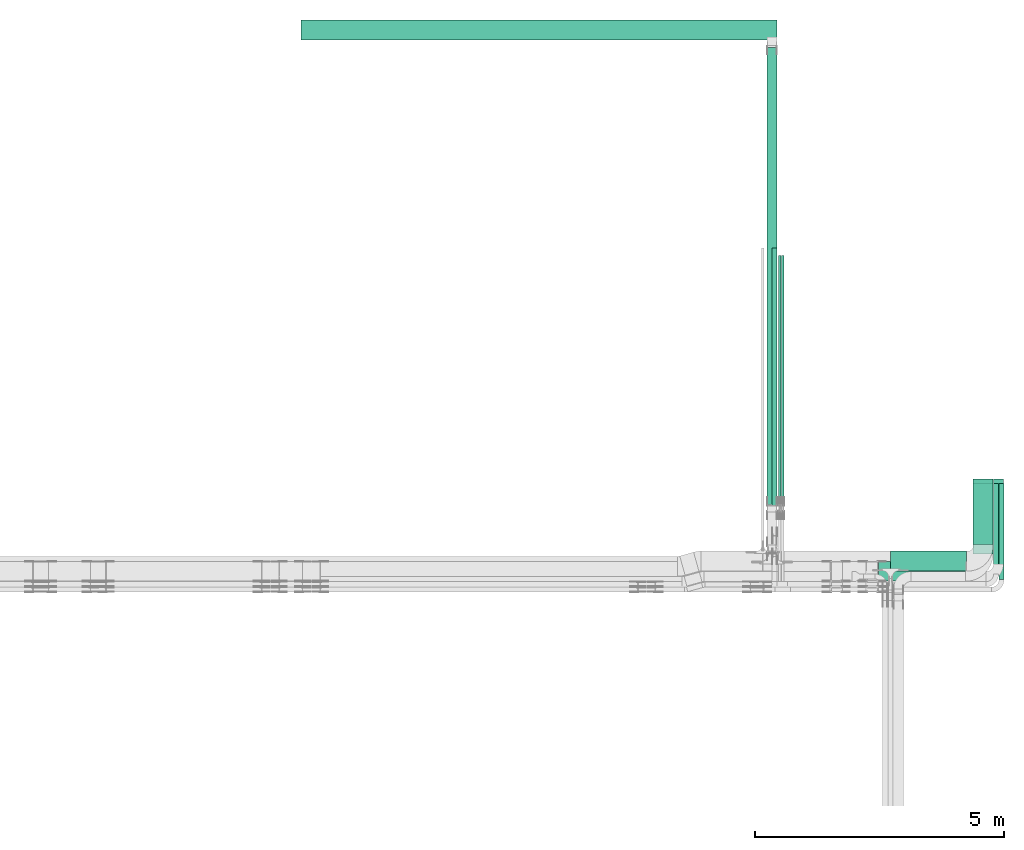
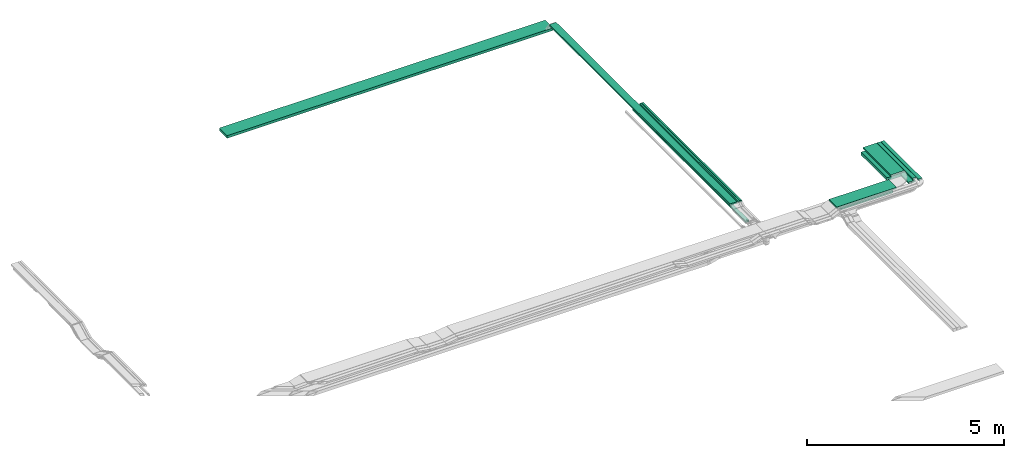
# One storey, part 3 of 27: 12 flow segments.
"""IFC2X3 building model written with IfcOpenShell, lengths in millimetres."""

from ifc_helpers import new_model, entity, si_unit, converted_unit, derived_unit, direction, frame, origin, origin_2d_with_axis, place, context, subcontext, project, spatial, rectangle, extrude, type_object, element, save


model = new_model("IFC2X3")

# Units and contexts
model_context = context("Model", 3, precision=0.01, world=origin(), true_north=direction((6.12303176911189e-17, 1.0)))
body_context = subcontext(model_context, "Body", "Model", "MODEL_VIEW")
ifc_project = project(units=[si_unit("LENGTHUNIT", "METRE", prefix="MILLI"), si_unit("AREAUNIT", "SQUARE_METRE"), si_unit("VOLUMEUNIT", "CUBIC_METRE"), converted_unit("PLANEANGLEUNIT", "DEGREE", entity("IfcRatioMeasure", 0.0174532925199433), si_unit("PLANEANGLEUNIT", "RADIAN"), dimensions=[0, 0, 0, 0, 0, 0, 0]), si_unit("MASSUNIT", "GRAM", prefix="KILO"), derived_unit("MASSDENSITYUNIT", [(si_unit("MASSUNIT", "GRAM", prefix="KILO"), 1), (si_unit("LENGTHUNIT", "METRE"), -3)]), derived_unit("MOMENTOFINERTIAUNIT", [(si_unit("LENGTHUNIT", "METRE"), 4)]), si_unit("TIMEUNIT", "SECOND"), si_unit("FREQUENCYUNIT", "HERTZ"), si_unit("THERMODYNAMICTEMPERATUREUNIT", "DEGREE_CELSIUS"), derived_unit("THERMALTRANSMITTANCEUNIT", [(si_unit("MASSUNIT", "GRAM", prefix="KILO"), 1), (si_unit("THERMODYNAMICTEMPERATUREUNIT", "KELVIN"), -1), (si_unit("TIMEUNIT", "SECOND"), -3)]), derived_unit("VOLUMETRICFLOWRATEUNIT", [(si_unit("LENGTHUNIT", "METRE"), 3), (si_unit("TIMEUNIT", "SECOND"), -1)]), derived_unit("MASSFLOWRATEUNIT", [(si_unit("MASSUNIT", "GRAM", prefix="KILO"), 1), (si_unit("TIMEUNIT", "SECOND"), -1)]), derived_unit("ROTATIONALFREQUENCYUNIT", [(si_unit("TIMEUNIT", "SECOND"), -1)]), si_unit("ELECTRICCURRENTUNIT", "AMPERE"), si_unit("ELECTRICVOLTAGEUNIT", "VOLT"), si_unit("POWERUNIT", "WATT"), si_unit("FORCEUNIT", "NEWTON", prefix="KILO"), si_unit("ILLUMINANCEUNIT", "LUX"), si_unit("LUMINOUSFLUXUNIT", "LUMEN"), si_unit("LUMINOUSINTENSITYUNIT", "CANDELA"), derived_unit("USERDEFINED", [(si_unit("MASSUNIT", "GRAM", prefix="KILO"), -1), (si_unit("LENGTHUNIT", "METRE"), -2), (si_unit("TIMEUNIT", "SECOND"), 3), (si_unit("LUMINOUSFLUXUNIT", "LUMEN"), 1)]), derived_unit("LINEARVELOCITYUNIT", [(si_unit("LENGTHUNIT", "METRE"), 1), (si_unit("TIMEUNIT", "SECOND"), -1)]), si_unit("PRESSUREUNIT", "PASCAL"), derived_unit("USERDEFINED", [(si_unit("LENGTHUNIT", "METRE"), -2), (si_unit("MASSUNIT", "GRAM", prefix="KILO"), 1), (si_unit("TIMEUNIT", "SECOND"), -2)]), derived_unit("LINEARFORCEUNIT", [(si_unit("MASSUNIT", "GRAM", prefix="KILO"), 1), (si_unit("LENGTHUNIT", "METRE"), 1), (si_unit("TIMEUNIT", "SECOND"), -2), (si_unit("LENGTHUNIT", "METRE"), -1)]), derived_unit("PLANARFORCEUNIT", [(si_unit("MASSUNIT", "GRAM", prefix="KILO"), 1), (si_unit("LENGTHUNIT", "METRE"), 1), (si_unit("TIMEUNIT", "SECOND"), -2), (si_unit("LENGTHUNIT", "METRE"), -2)])], contexts=[model_context])

# Site, building, storey
site_placement = place(None, origin())
site = spatial("IfcSite", under=ifc_project, at=site_placement, CompositionType="ELEMENT")
building_placement = place(site_placement, origin())
building = spatial("IfcBuilding", under=site, at=building_placement, CompositionType="ELEMENT")
storey_placement = place(building_placement, origin())
storey = spatial("IfcBuildingStorey", under=building, at=storey_placement, CompositionType="ELEMENT", Elevation=0.0)

# Flow segments
cable_carrier_segment_type = type_object("IfcCableCarrierSegmentType", PredefinedType="CABLETRAYSEGMENT")
flow_segment_1_placement = place(storey_placement, frame((64007.77, 9444.27, 2600.0)))
element("IfcFlowSegment", 1, at=flow_segment_1_placement, inside=storey, type_object=cable_carrier_segment_type, context=body_context, shape_type="SweptSolid", body=[
    extrude(rectangle(XDim=5768.12467532729, YDim=99.9999999999946, at=origin_2d_with_axis()), frame((50.0, 2884.06, 0.0), z_axis=(0.0, 0.0, 1.0), x_axis=(0.0, 1.0, 0.0)), (0.0, 0.0, 1.0), 49.9999999999995),
])
flow_segment_2_placement = place(storey_placement, frame((64197.18, 10059.65, 2800.0)))
element("IfcFlowSegment", 2, at=flow_segment_2_placement, inside=storey, type_object=cable_carrier_segment_type, context=body_context, shape_type="SweptSolid", body=[
    extrude(rectangle(XDim=5010.35026677283, YDim=50.000000000006, at=origin_2d_with_axis()), frame((25.0, 2505.18, 0.0), z_axis=(0.0, 0.0, 1.0), x_axis=(0.0, 1.0, 0.0)), (0.0, 0.0, 1.0), 50.0000000000005),
])
flow_segment_3_placement = place(storey_placement, frame((64137.18, 10059.65, 2800.0)))
element("IfcFlowSegment", 3, at=flow_segment_3_placement, inside=storey, type_object=cable_carrier_segment_type, context=body_context, shape_type="SweptSolid", body=[
    extrude(rectangle(XDim=5010.3502667718, YDim=50.000000000006, at=origin_2d_with_axis()), frame((25.0, 2505.18, 0.0), z_axis=(0.0, 0.0, 1.0), x_axis=(0.0, 1.0, 0.0)), (0.0, 0.0, 1.0), 50.0000000000005),
])
flow_segment_4_placement = place(storey_placement, frame((68046.01, 9254.33, 2600.0)))
element("IfcFlowSegment", 4, at=flow_segment_4_placement, inside=storey, type_object=cable_carrier_segment_type, context=body_context, shape_type="SweptSolid", body=[
    extrude(rectangle(XDim=1317.94944193116, YDim=399.999999999996, at=origin_2d_with_axis()), frame((200.0, 658.97, 0.0), z_axis=(0.0, 0.0, 1.0), x_axis=(0.0, -1.0, 0.0)), (0.0, 0.0, 1.0), 100.000000000001),
])
flow_segment_5_placement = place(storey_placement, frame((66386.0, 8724.33, 2600.0)))
element("IfcFlowSegment", 5, at=flow_segment_5_placement, inside=storey, type_object=cable_carrier_segment_type, context=body_context, shape_type="SweptSolid", body=[
    extrude(rectangle(XDim=1530.01217238575, YDim=400.0, at=origin_2d_with_axis()), frame((765.01, 200.0, 0.0), z_axis=(0.0, 0.0, 1.0), x_axis=(-1.0, 0.0, 0.0)), (0.0, 0.0, 1.0), 100.0),
])
flow_segment_6_placement = place(storey_placement, frame((66145.26, 8520.0, 2850.0)))
element("IfcFlowSegment", 6, at=flow_segment_6_placement, inside=storey, type_object=cable_carrier_segment_type, context=body_context, shape_type="SweptSolid", body=[
    extrude(rectangle(XDim=1749.75324383906, YDim=400.0, at=origin_2d_with_axis()), frame((874.88, 200.0, 0.0), z_axis=(0.0, 0.0, 1.0), x_axis=(-1.0, 0.0, 0.0)), (0.0, 0.0, 1.0), 49.9999999999995),
])
flow_segment_7_placement = place(storey_placement, frame((68046.01, 9071.0, 2850.0)))
element("IfcFlowSegment", 7, at=flow_segment_7_placement, inside=storey, type_object=cable_carrier_segment_type, context=body_context, shape_type="SweptSolid", body=[
    extrude(rectangle(XDim=1408.99999999999, YDim=399.999999999996, at=origin_2d_with_axis()), frame((200.0, 704.5, 0.0), z_axis=(0.0, 0.0, 1.0), x_axis=(0.0, 1.0, 0.0)), (0.0, 0.0, 1.0), 49.9999999999995),
])
flow_segment_8_placement = place(storey_placement, frame((68456.01, 8661.0, 2850.0)))
element("IfcFlowSegment", 8, at=flow_segment_8_placement, inside=storey, type_object=cable_carrier_segment_type, context=body_context, shape_type="SweptSolid", body=[
    extrude(rectangle(XDim=1818.99999999993, YDim=99.9999999999946, at=origin_2d_with_axis()), frame((50.0, 909.5, 0.0), z_axis=(0.0, 0.0, 1.0), x_axis=(0.0, 1.0, 0.0)), (0.0, 0.0, 1.0), 49.9999999999995),
])
flow_segment_9_placement = place(storey_placement, frame((68566.01, 8551.0, 2850.0)))
element("IfcFlowSegment", 9, at=flow_segment_9_placement, inside=storey, type_object=cable_carrier_segment_type, context=body_context, shape_type="SweptSolid", body=[
    extrude(rectangle(XDim=1928.99999999997, YDim=99.9999999999946, at=origin_2d_with_axis()), frame((50.0, 964.5, 0.0), z_axis=(0.0, 0.0, 1.0), x_axis=(0.0, 1.0, 0.0)), (0.0, 0.0, 1.0), 49.9999999999995),
])
flow_segment_10_placement = place(storey_placement, frame((68456.01, 8865.33, 2600.0)))
element("IfcFlowSegment", 10, at=flow_segment_10_placement, inside=storey, type_object=cable_carrier_segment_type, context=body_context, shape_type="SweptSolid", body=[
    extrude(rectangle(XDim=1706.94944193117, YDim=200.000000000007, at=origin_2d_with_axis()), frame((100.0, 853.47, 0.0), z_axis=(0.0, 0.0, 1.0), x_axis=(0.0, -1.0, 0.0)), (0.0, 0.0, 1.0), 49.9999999999995),
])
flow_segment_11_placement = place(storey_placement, frame((54539.06, 19400.0, 2500.0)))
element("IfcFlowSegment", 11, at=flow_segment_11_placement, inside=storey, type_object=cable_carrier_segment_type, context=body_context, shape_type="SweptSolid", body=[
    extrude(rectangle(XDim=9563.12444866768, YDim=400.000000000002, at=origin_2d_with_axis()), frame((4781.56, 200.0, 0.0), z_axis=(0.0, 0.0, 1.0), x_axis=(-1.0, 0.0, 0.0)), (0.0, 0.0, 1.0), 80.0000000000002),
])
flow_segment_12_placement = place(storey_placement, frame((63902.18, 10059.65, 2800.0)))
element("IfcFlowSegment", 12, at=flow_segment_12_placement, inside=storey, type_object=cable_carrier_segment_type, context=body_context, shape_type="SweptSolid", body=[
    extrude(rectangle(XDim=9184.86114375628, YDim=200.000000000007, at=origin_2d_with_axis()), frame((100.0, 4592.43, 0.0), z_axis=(0.0, 0.0, 1.0), x_axis=(0.0, 1.0, 0.0)), (0.0, 0.0, 1.0), 50.0000000000005),
])

save(model, "model.ifc")
